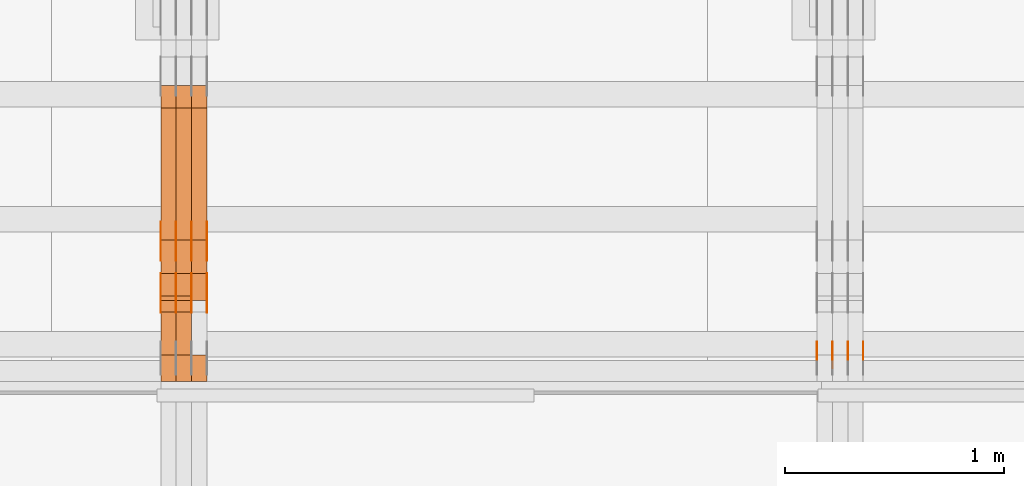
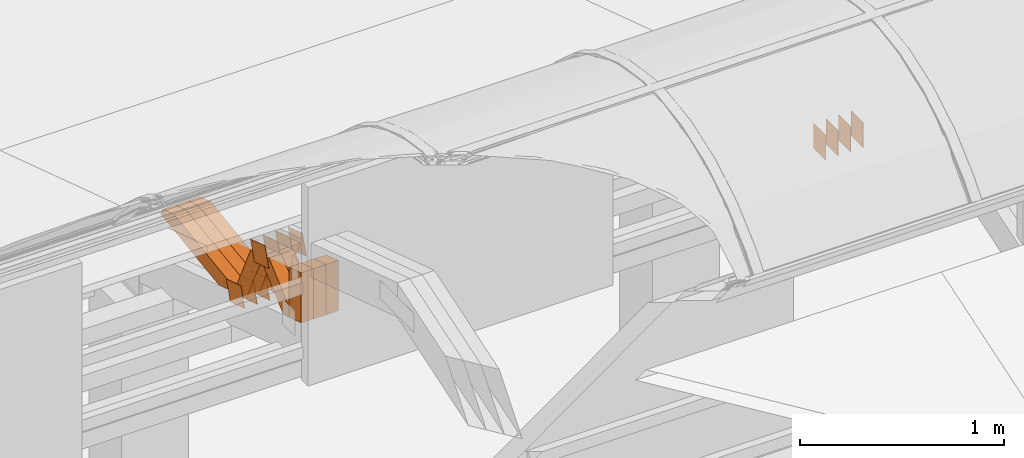
# One storey, part 289 of 385: 29 proxies.
"""IFC2X3 building model written with IfcOpenShell, lengths in millimetres."""

from ifc_helpers import new_model, entity, si_unit, converted_unit, derived_unit, direction, frame, origin, origin_2d_with_axis, place, context, subcontext, project, spatial, polyline, rectangle, outline, extrude, source, transform, mapped, material, type_object, type_shapes, element, save


model = new_model("IFC2X3")

# Units and contexts
model_context = context("Model", 3, precision=0.01, world=origin(), true_north=direction((6.12303176911189e-17, 1.0)))
body_context = subcontext(model_context, "Body", "Model", "MODEL_VIEW")
ifc_project = project(units=[si_unit("LENGTHUNIT", "METRE", prefix="MILLI"), si_unit("AREAUNIT", "SQUARE_METRE"), si_unit("VOLUMEUNIT", "CUBIC_METRE"), converted_unit("PLANEANGLEUNIT", "DEGREE", entity("IfcRatioMeasure", 0.0174532925199433), si_unit("PLANEANGLEUNIT", "RADIAN"), dimensions=[0, 0, 0, 0, 0, 0, 0]), si_unit("MASSUNIT", "GRAM", prefix="KILO"), derived_unit("MASSDENSITYUNIT", [(si_unit("MASSUNIT", "GRAM", prefix="KILO"), 1), (si_unit("LENGTHUNIT", "METRE"), -3)]), si_unit("TIMEUNIT", "SECOND"), si_unit("FREQUENCYUNIT", "HERTZ"), si_unit("THERMODYNAMICTEMPERATUREUNIT", "DEGREE_CELSIUS"), derived_unit("THERMALTRANSMITTANCEUNIT", [(si_unit("MASSUNIT", "GRAM", prefix="KILO"), 1), (si_unit("THERMODYNAMICTEMPERATUREUNIT", "KELVIN"), -1), (si_unit("TIMEUNIT", "SECOND"), -3)]), derived_unit("VOLUMETRICFLOWRATEUNIT", [(si_unit("LENGTHUNIT", "METRE"), 3), (si_unit("TIMEUNIT", "SECOND"), -1)]), si_unit("ELECTRICCURRENTUNIT", "AMPERE"), si_unit("ELECTRICVOLTAGEUNIT", "VOLT"), si_unit("POWERUNIT", "WATT"), si_unit("FORCEUNIT", "NEWTON", prefix="KILO"), si_unit("ILLUMINANCEUNIT", "LUX"), si_unit("LUMINOUSFLUXUNIT", "LUMEN"), si_unit("LUMINOUSINTENSITYUNIT", "CANDELA"), derived_unit("USERDEFINED", [(si_unit("MASSUNIT", "GRAM", prefix="KILO"), -1), (si_unit("LENGTHUNIT", "METRE"), -2), (si_unit("TIMEUNIT", "SECOND"), 3), (si_unit("LUMINOUSFLUXUNIT", "LUMEN"), 1)]), derived_unit("LINEARVELOCITYUNIT", [(si_unit("LENGTHUNIT", "METRE"), 1), (si_unit("TIMEUNIT", "SECOND"), -1)]), si_unit("PRESSUREUNIT", "PASCAL"), derived_unit("USERDEFINED", [(si_unit("LENGTHUNIT", "METRE"), -2), (si_unit("MASSUNIT", "GRAM", prefix="KILO"), 1), (si_unit("TIMEUNIT", "SECOND"), -2)])], contexts=[model_context])

# Site, building, storey
site_placement = place(None, origin())
site = spatial("IfcSite", under=ifc_project, at=site_placement, CompositionType="ELEMENT")
building_placement = place(site_placement, origin())
building = spatial("IfcBuilding", under=site, at=building_placement, CompositionType="ELEMENT")
storey_placement = place(building_placement, origin())
storey = spatial("IfcBuildingStorey", under=building, at=storey_placement, Name="Default", CompositionType="ELEMENT", Elevation=0.0)

# Proxies
ifc_material_1 = material(Name="IfcSurfaceStyle #480834")
building_element_proxy_type_1 = type_object("IfcBuildingElementProxyType", PredefinedType="NOTDEFINED", material=ifc_material_1)
shared_shape_1 = source(origin(), body_context, "Body", "SweptSolid", [
    extrude(rectangle(XDim=150.0, YDim=120.0, at=origin_2d_with_axis()), frame((75.0, 60.0, 0.0), z_axis=(0.0, 0.0, 1.0), x_axis=(-1.0, 0.0, 0.0)), (0.0, 0.0, 1.0), 1.3),
])
type_shapes(building_element_proxy_type_1, [shared_shape_1])
proxy_1_placement = place(building_placement, frame((39386.3, 15840.0, 3652.70166015625), z_axis=(-1.0, 0.0, 0.0), x_axis=(0.0, 0.0, -1.0)))
element("IfcBuildingElementProxy", 1, at=proxy_1_placement, inside=storey, type_object=building_element_proxy_type_1, material=ifc_material_1, context=body_context, shape_type="MappedRepresentation", body=[
    mapped(shared_shape_1, transform((0.0, 0.0, 0.0), scale=1.0)),
])
ifc_material_2 = material(Name="IfcSurfaceStyle #480777")
building_element_proxy_type_2 = type_object("IfcBuildingElementProxyType", PredefinedType="NOTDEFINED", material=ifc_material_2)
shared_shape_2 = source(origin(), body_context, "Body", "SweptSolid", [
    extrude(rectangle(XDim=150.0, YDim=120.0, at=origin_2d_with_axis()), frame((75.0, 60.0, 0.0), z_axis=(0.0, 0.0, 1.0), x_axis=(-1.0, 0.0, 0.0)), (0.0, 0.0, 1.0), 1.3),
])
type_shapes(building_element_proxy_type_2, [shared_shape_2])
proxy_2_placement = place(building_placement, frame((39315.0, 15840.0, 3652.70166015625), z_axis=(-1.0, 0.0, 0.0), x_axis=(0.0, 0.0, -1.0)))
element("IfcBuildingElementProxy", 2, at=proxy_2_placement, inside=storey, type_object=building_element_proxy_type_2, material=ifc_material_2, context=body_context, shape_type="MappedRepresentation", body=[
    mapped(shared_shape_2, transform((0.0, 0.0, 0.0), scale=1.0)),
])
ifc_material_3 = material(Name="IfcSurfaceStyle #480720")
building_element_proxy_type_3 = type_object("IfcBuildingElementProxyType", PredefinedType="NOTDEFINED", material=ifc_material_3)
shared_shape_3 = source(origin(), body_context, "Body", "SweptSolid", [
    extrude(rectangle(XDim=150.0, YDim=120.0, at=origin_2d_with_axis()), frame((75.0, 60.0, 0.0), z_axis=(0.0, 0.0, 1.0), x_axis=(-1.0, 0.0, 0.0)), (0.0, 0.0, 1.0), 1.3),
])
type_shapes(building_element_proxy_type_3, [shared_shape_3])
proxy_3_placement = place(building_placement, frame((39316.3, 15840.0, 3652.70166015625), z_axis=(-1.0, 0.0, 0.0), x_axis=(0.0, 0.0, -1.0)))
element("IfcBuildingElementProxy", 3, at=proxy_3_placement, inside=storey, type_object=building_element_proxy_type_3, material=ifc_material_3, context=body_context, shape_type="MappedRepresentation", body=[
    mapped(shared_shape_3, transform((0.0, 0.0, 0.0), scale=1.0)),
])
ifc_material_4 = material(Name="IfcSurfaceStyle #480663")
building_element_proxy_type_4 = type_object("IfcBuildingElementProxyType", PredefinedType="NOTDEFINED", material=ifc_material_4)
shared_shape_4 = source(origin(), body_context, "Body", "SweptSolid", [
    extrude(rectangle(XDim=150.0, YDim=120.0, at=origin_2d_with_axis()), frame((75.0, 60.0, 0.0), z_axis=(0.0, 0.0, 1.0), x_axis=(-1.0, 0.0, 0.0)), (0.0, 0.0, 1.0), 1.29999999999999),
])
type_shapes(building_element_proxy_type_4, [shared_shape_4])
proxy_4_placement = place(building_placement, frame((39245.0, 15840.0, 3652.70166015625), z_axis=(-1.0, 0.0, 0.0), x_axis=(0.0, 0.0, -1.0)))
element("IfcBuildingElementProxy", 4, at=proxy_4_placement, inside=storey, type_object=building_element_proxy_type_4, material=ifc_material_4, context=body_context, shape_type="MappedRepresentation", body=[
    mapped(shared_shape_4, transform((0.0, 0.0, 0.0), scale=1.0)),
])
ifc_material_5 = material(Name="IfcSurfaceStyle #480606")
building_element_proxy_type_5 = type_object("IfcBuildingElementProxyType", PredefinedType="NOTDEFINED", material=ifc_material_5)
shared_shape_5 = source(origin(), body_context, "Body", "SweptSolid", [
    extrude(rectangle(XDim=150.0, YDim=120.0, at=origin_2d_with_axis()), frame((75.0, 60.0, 0.0), z_axis=(0.0, 0.0, 1.0), x_axis=(-1.0, 0.0, 0.0)), (0.0, 0.0, 1.0), 1.29999999999999),
])
type_shapes(building_element_proxy_type_5, [shared_shape_5])
proxy_5_placement = place(building_placement, frame((39246.3, 15840.0, 3652.70166015625), z_axis=(-1.0, 0.0, 0.0), x_axis=(0.0, 0.0, -1.0)))
element("IfcBuildingElementProxy", 5, at=proxy_5_placement, inside=storey, type_object=building_element_proxy_type_5, material=ifc_material_5, context=body_context, shape_type="MappedRepresentation", body=[
    mapped(shared_shape_5, transform((0.0, 0.0, 0.0), scale=1.0)),
])
ifc_material_6 = material(Name="IfcSurfaceStyle #480549")
building_element_proxy_type_6 = type_object("IfcBuildingElementProxyType", PredefinedType="NOTDEFINED", material=ifc_material_6)
shared_shape_6 = source(origin(), body_context, "Body", "SweptSolid", [
    extrude(rectangle(XDim=150.0, YDim=120.0, at=origin_2d_with_axis()), frame((75.0, 60.0, 0.0), z_axis=(0.0, 0.0, 1.0), x_axis=(-1.0, 0.0, 0.0)), (0.0, 0.0, 1.0), 1.29999999999999),
])
type_shapes(building_element_proxy_type_6, [shared_shape_6])
proxy_6_placement = place(building_placement, frame((39175.0, 15840.0, 3652.70166015625), z_axis=(-1.0, 0.0, 0.0), x_axis=(0.0, 0.0, -1.0)))
element("IfcBuildingElementProxy", 6, at=proxy_6_placement, inside=storey, type_object=building_element_proxy_type_6, material=ifc_material_6, context=body_context, shape_type="MappedRepresentation", body=[
    mapped(shared_shape_6, transform((0.0, 0.0, 0.0), scale=1.0)),
])
ifc_material_7 = material(Name="IfcSurfaceStyle #446060")
building_element_proxy_type_7 = type_object("IfcBuildingElementProxyType", PredefinedType="NOTDEFINED", material=ifc_material_7)
shared_shape_7 = source(origin(), body_context, "Body", "SweptSolid", [
    extrude(outline(polyline([(-74.9998605591118, -59.9999264677601), (74.9998754286171, -59.9999264677601), (74.9998605591118, 59.9999264677602), (-74.9998754286171, 59.9999264677602), (-74.9998605591118, -59.9999264677601)])), frame((74.9998754286171, 60.0000503992849, 0.0), z_axis=(0.0, 0.0, 1.0), x_axis=(-1.0, 0.0, 0.0)), (0.0, 0.0, 1.0), 1.3),
])
type_shapes(building_element_proxy_type_7, [shared_shape_7])
proxy_7_placement = place(building_placement, frame((36386.3, 16352.8320303235, 3323.23212676408), z_axis=(-1.0, 0.0, 0.0), x_axis=(0.0, -0.951056516295124, 0.309016994375039)))
element("IfcBuildingElementProxy", 7, at=proxy_7_placement, inside=storey, type_object=building_element_proxy_type_7, material=ifc_material_7, context=body_context, shape_type="MappedRepresentation", body=[
    mapped(shared_shape_7, transform((0.0, 0.0, 0.0), scale=1.0)),
])
ifc_material_8 = material(Name="IfcSurfaceStyle #446003")
building_element_proxy_type_8 = type_object("IfcBuildingElementProxyType", PredefinedType="NOTDEFINED", material=ifc_material_8)
shared_shape_8 = source(origin(), body_context, "Body", "SweptSolid", [
    extrude(outline(polyline([(-74.9998605591118, -59.9999264677601), (74.9998754286171, -59.9999264677601), (74.9998605591118, 59.9999264677602), (-74.9998754286171, 59.9999264677602), (-74.9998605591118, -59.9999264677601)])), frame((74.9998754286171, 60.0000503992849, 0.0), z_axis=(0.0, 0.0, 1.0), x_axis=(-1.0, 0.0, 0.0)), (0.0, 0.0, 1.0), 1.3),
])
type_shapes(building_element_proxy_type_8, [shared_shape_8])
proxy_8_placement = place(building_placement, frame((36315.0, 16352.8320303235, 3323.23212676408), z_axis=(-1.0, 0.0, 0.0), x_axis=(0.0, -0.951056516295124, 0.309016994375039)))
element("IfcBuildingElementProxy", 8, at=proxy_8_placement, inside=storey, type_object=building_element_proxy_type_8, material=ifc_material_8, context=body_context, shape_type="MappedRepresentation", body=[
    mapped(shared_shape_8, transform((0.0, 0.0, 0.0), scale=1.0)),
])
ifc_material_9 = material(Name="IfcSurfaceStyle #445946")
building_element_proxy_type_9 = type_object("IfcBuildingElementProxyType", PredefinedType="NOTDEFINED", material=ifc_material_9)
shared_shape_9 = source(origin(), body_context, "Body", "SweptSolid", [
    extrude(outline(polyline([(-74.9998605591118, -59.9999264677601), (74.9998754286171, -59.9999264677601), (74.9998605591118, 59.9999264677602), (-74.9998754286171, 59.9999264677602), (-74.9998605591118, -59.9999264677601)])), frame((74.9998754286171, 60.0000503992849, 0.0), z_axis=(0.0, 0.0, 1.0), x_axis=(-1.0, 0.0, 0.0)), (0.0, 0.0, 1.0), 1.3),
])
type_shapes(building_element_proxy_type_9, [shared_shape_9])
proxy_9_placement = place(building_placement, frame((36316.3, 16352.8320303235, 3323.23212676408), z_axis=(-1.0, 0.0, 0.0), x_axis=(0.0, -0.951056516295124, 0.309016994375039)))
element("IfcBuildingElementProxy", 9, at=proxy_9_placement, inside=storey, type_object=building_element_proxy_type_9, material=ifc_material_9, context=body_context, shape_type="MappedRepresentation", body=[
    mapped(shared_shape_9, transform((0.0, 0.0, 0.0), scale=1.0)),
])
ifc_material_10 = material(Name="IfcSurfaceStyle #445889")
building_element_proxy_type_10 = type_object("IfcBuildingElementProxyType", PredefinedType="NOTDEFINED", material=ifc_material_10)
shared_shape_10 = source(origin(), body_context, "Body", "SweptSolid", [
    extrude(outline(polyline([(-74.9998605591118, -59.9999264677601), (74.9998754286171, -59.9999264677601), (74.9998605591118, 59.9999264677602), (-74.9998754286171, 59.9999264677602), (-74.9998605591118, -59.9999264677601)])), frame((74.9998754286171, 60.0000503992849, 0.0), z_axis=(0.0, 0.0, 1.0), x_axis=(-1.0, 0.0, 0.0)), (0.0, 0.0, 1.0), 1.29999999999999),
])
type_shapes(building_element_proxy_type_10, [shared_shape_10])
proxy_10_placement = place(building_placement, frame((36245.0, 16352.8320303235, 3323.23212676408), z_axis=(-1.0, 0.0, 0.0), x_axis=(0.0, -0.951056516295124, 0.309016994375039)))
element("IfcBuildingElementProxy", 10, at=proxy_10_placement, inside=storey, type_object=building_element_proxy_type_10, material=ifc_material_10, context=body_context, shape_type="MappedRepresentation", body=[
    mapped(shared_shape_10, transform((0.0, 0.0, 0.0), scale=1.0)),
])
ifc_material_11 = material(Name="IfcSurfaceStyle #445832")
building_element_proxy_type_11 = type_object("IfcBuildingElementProxyType", PredefinedType="NOTDEFINED", material=ifc_material_11)
shared_shape_11 = source(origin(), body_context, "Body", "SweptSolid", [
    extrude(outline(polyline([(-74.9998605591118, -59.9999264677601), (74.9998754286171, -59.9999264677601), (74.9998605591118, 59.9999264677602), (-74.9998754286171, 59.9999264677602), (-74.9998605591118, -59.9999264677601)])), frame((74.9998754286171, 60.0000503992849, 0.0), z_axis=(0.0, 0.0, 1.0), x_axis=(-1.0, 0.0, 0.0)), (0.0, 0.0, 1.0), 1.29999999999999),
])
type_shapes(building_element_proxy_type_11, [shared_shape_11])
proxy_11_placement = place(building_placement, frame((36246.3, 16352.8320303235, 3323.23212676408), z_axis=(-1.0, 0.0, 0.0), x_axis=(0.0, -0.951056516295124, 0.309016994375039)))
element("IfcBuildingElementProxy", 11, at=proxy_11_placement, inside=storey, type_object=building_element_proxy_type_11, material=ifc_material_11, context=body_context, shape_type="MappedRepresentation", body=[
    mapped(shared_shape_11, transform((0.0, 0.0, 0.0), scale=1.0)),
])
ifc_material_12 = material(Name="IfcSurfaceStyle #445775")
building_element_proxy_type_12 = type_object("IfcBuildingElementProxyType", PredefinedType="NOTDEFINED", material=ifc_material_12)
shared_shape_12 = source(origin(), body_context, "Body", "SweptSolid", [
    extrude(outline(polyline([(-74.9998605591118, -59.9999264677601), (74.9998754286171, -59.9999264677601), (74.9998605591118, 59.9999264677602), (-74.9998754286171, 59.9999264677602), (-74.9998605591118, -59.9999264677601)])), frame((74.9998754286171, 60.0000503992849, 0.0), z_axis=(0.0, 0.0, 1.0), x_axis=(-1.0, 0.0, 0.0)), (0.0, 0.0, 1.0), 1.29999999999999),
])
type_shapes(building_element_proxy_type_12, [shared_shape_12])
proxy_12_placement = place(building_placement, frame((36175.0, 16352.8320303235, 3323.23212676408), z_axis=(-1.0, 0.0, 0.0), x_axis=(0.0, -0.951056516295124, 0.309016994375039)))
element("IfcBuildingElementProxy", 12, at=proxy_12_placement, inside=storey, type_object=building_element_proxy_type_12, material=ifc_material_12, context=body_context, shape_type="MappedRepresentation", body=[
    mapped(shared_shape_12, transform((0.0, 0.0, 0.0), scale=1.0)),
])
ifc_material_13 = material(Name="IfcSurfaceStyle #441614")
building_element_proxy_type_13 = type_object("IfcBuildingElementProxyType", PredefinedType="NOTDEFINED", material=ifc_material_13)
shared_shape_13 = source(origin(), body_context, "Body", "SweptSolid", [
    extrude(outline(polyline([(-75.0003249421702, -60.0000773549573), (75.0003398116874, -60.0000773549573), (75.0003249421711, 60.0000773549573), (-75.0003398116883, 60.0000773549573), (-75.0003249421702, -60.0000773549573)])), frame((75.0003398116874, 60.0000773549573, 0.0), z_axis=(0.0, 0.0, 1.0), x_axis=(-1.0, 0.0, 0.0)), (0.0, 0.0, 1.0), 1.3),
])
type_shapes(building_element_proxy_type_13, [shared_shape_13])
proxy_13_placement = place(building_placement, frame((36386.3, 16117.0849050545, 3705.49074668796), z_axis=(-1.0, 0.0, 0.0), x_axis=(0.0, -0.951056516295154, 0.309016994374948)))
element("IfcBuildingElementProxy", 13, at=proxy_13_placement, inside=storey, type_object=building_element_proxy_type_13, material=ifc_material_13, context=body_context, shape_type="MappedRepresentation", body=[
    mapped(shared_shape_13, transform((0.0, 0.0, 0.0), scale=1.0)),
])
ifc_material_14 = material(Name="IfcSurfaceStyle #441557")
building_element_proxy_type_14 = type_object("IfcBuildingElementProxyType", PredefinedType="NOTDEFINED", material=ifc_material_14)
shared_shape_14 = source(origin(), body_context, "Body", "SweptSolid", [
    extrude(outline(polyline([(-75.0003249421702, -60.0000773549573), (75.0003398116874, -60.0000773549573), (75.0003249421711, 60.0000773549573), (-75.0003398116883, 60.0000773549573), (-75.0003249421702, -60.0000773549573)])), frame((75.0003398116874, 60.0000773549573, 0.0), z_axis=(0.0, 0.0, 1.0), x_axis=(-1.0, 0.0, 0.0)), (0.0, 0.0, 1.0), 1.3),
])
type_shapes(building_element_proxy_type_14, [shared_shape_14])
proxy_14_placement = place(building_placement, frame((36315.0, 16117.0849050545, 3705.49074668796), z_axis=(-1.0, 0.0, 0.0), x_axis=(0.0, -0.951056516295154, 0.309016994374948)))
element("IfcBuildingElementProxy", 14, at=proxy_14_placement, inside=storey, type_object=building_element_proxy_type_14, material=ifc_material_14, context=body_context, shape_type="MappedRepresentation", body=[
    mapped(shared_shape_14, transform((0.0, 0.0, 0.0), scale=1.0)),
])
ifc_material_15 = material(Name="IfcSurfaceStyle #441500")
building_element_proxy_type_15 = type_object("IfcBuildingElementProxyType", PredefinedType="NOTDEFINED", material=ifc_material_15)
shared_shape_15 = source(origin(), body_context, "Body", "SweptSolid", [
    extrude(outline(polyline([(-75.0003249421702, -60.0000773549573), (75.0003398116874, -60.0000773549573), (75.0003249421711, 60.0000773549573), (-75.0003398116883, 60.0000773549573), (-75.0003249421702, -60.0000773549573)])), frame((75.0003398116874, 60.0000773549573, 0.0), z_axis=(0.0, 0.0, 1.0), x_axis=(-1.0, 0.0, 0.0)), (0.0, 0.0, 1.0), 1.3),
])
type_shapes(building_element_proxy_type_15, [shared_shape_15])
proxy_15_placement = place(building_placement, frame((36316.3, 16117.0849050545, 3705.49074668796), z_axis=(-1.0, 0.0, 0.0), x_axis=(0.0, -0.951056516295154, 0.309016994374948)))
element("IfcBuildingElementProxy", 15, at=proxy_15_placement, inside=storey, type_object=building_element_proxy_type_15, material=ifc_material_15, context=body_context, shape_type="MappedRepresentation", body=[
    mapped(shared_shape_15, transform((0.0, 0.0, 0.0), scale=1.0)),
])
ifc_material_16 = material(Name="IfcSurfaceStyle #441443")
building_element_proxy_type_16 = type_object("IfcBuildingElementProxyType", PredefinedType="NOTDEFINED", material=ifc_material_16)
shared_shape_16 = source(origin(), body_context, "Body", "SweptSolid", [
    extrude(outline(polyline([(-75.0003249421702, -60.0000773549573), (75.0003398116874, -60.0000773549573), (75.0003249421711, 60.0000773549573), (-75.0003398116883, 60.0000773549573), (-75.0003249421702, -60.0000773549573)])), frame((75.0003398116874, 60.0000773549573, 0.0), z_axis=(0.0, 0.0, 1.0), x_axis=(-1.0, 0.0, 0.0)), (0.0, 0.0, 1.0), 1.29999999999999),
])
type_shapes(building_element_proxy_type_16, [shared_shape_16])
proxy_16_placement = place(building_placement, frame((36245.0, 16117.0849050545, 3705.49074668796), z_axis=(-1.0, 0.0, 0.0), x_axis=(0.0, -0.951056516295154, 0.309016994374948)))
element("IfcBuildingElementProxy", 16, at=proxy_16_placement, inside=storey, type_object=building_element_proxy_type_16, material=ifc_material_16, context=body_context, shape_type="MappedRepresentation", body=[
    mapped(shared_shape_16, transform((0.0, 0.0, 0.0), scale=1.0)),
])
ifc_material_17 = material(Name="IfcSurfaceStyle #441386")
building_element_proxy_type_17 = type_object("IfcBuildingElementProxyType", PredefinedType="NOTDEFINED", material=ifc_material_17)
shared_shape_17 = source(origin(), body_context, "Body", "SweptSolid", [
    extrude(outline(polyline([(-75.0003249421702, -60.0000773549573), (75.0003398116874, -60.0000773549573), (75.0003249421711, 60.0000773549573), (-75.0003398116883, 60.0000773549573), (-75.0003249421702, -60.0000773549573)])), frame((75.0003398116874, 60.0000773549573, 0.0), z_axis=(0.0, 0.0, 1.0), x_axis=(-1.0, 0.0, 0.0)), (0.0, 0.0, 1.0), 1.29999999999999),
])
type_shapes(building_element_proxy_type_17, [shared_shape_17])
proxy_17_placement = place(building_placement, frame((36246.3, 16117.0849050545, 3705.49074668796), z_axis=(-1.0, 0.0, 0.0), x_axis=(0.0, -0.951056516295154, 0.309016994374948)))
element("IfcBuildingElementProxy", 17, at=proxy_17_placement, inside=storey, type_object=building_element_proxy_type_17, material=ifc_material_17, context=body_context, shape_type="MappedRepresentation", body=[
    mapped(shared_shape_17, transform((0.0, 0.0, 0.0), scale=1.0)),
])
ifc_material_18 = material(Name="IfcSurfaceStyle #441329")
building_element_proxy_type_18 = type_object("IfcBuildingElementProxyType", PredefinedType="NOTDEFINED", material=ifc_material_18)
shared_shape_18 = source(origin(), body_context, "Body", "SweptSolid", [
    extrude(outline(polyline([(-75.0003249421702, -60.0000773549573), (75.0003398116874, -60.0000773549573), (75.0003249421711, 60.0000773549573), (-75.0003398116883, 60.0000773549573), (-75.0003249421702, -60.0000773549573)])), frame((75.0003398116874, 60.0000773549573, 0.0), z_axis=(0.0, 0.0, 1.0), x_axis=(-1.0, 0.0, 0.0)), (0.0, 0.0, 1.0), 1.29999999999999),
])
type_shapes(building_element_proxy_type_18, [shared_shape_18])
proxy_18_placement = place(building_placement, frame((36175.0, 16117.0849050545, 3705.49074668796), z_axis=(-1.0, 0.0, 0.0), x_axis=(0.0, -0.951056516295154, 0.309016994374948)))
element("IfcBuildingElementProxy", 18, at=proxy_18_placement, inside=storey, type_object=building_element_proxy_type_18, material=ifc_material_18, context=body_context, shape_type="MappedRepresentation", body=[
    mapped(shared_shape_18, transform((0.0, 0.0, 0.0), scale=1.0)),
])
ifc_material_19 = material(Name="IfcSurfaceStyle #431486")
building_element_proxy_type_19 = type_object("IfcBuildingElementProxyType", Name="T1-W50 431484", PredefinedType="NOTDEFINED", material=ifc_material_19)
shared_shape_19 = source(origin(), body_context, "Body", "SweptSolid", [
    extrude(outline(polyline([(-128.56619634284, -47.4999385885712), (133.151257249084, -47.4999385885712), (161.172800006526, -0.000129729183733609), (147.291467726413, 47.500068317755), (-142.513973767368, 47.500068317755), (-170.535354871815, -0.000129729183754689), (-128.56619634284, -47.4999385885712)])), frame((161.17310141218, 47.5001898716564, 0.0), z_axis=(0.0, 0.0, 1.0), x_axis=(-1.0, 0.0, 0.0)), (0.0, 0.0, 1.0), 70.0),
])
type_shapes(building_element_proxy_type_19, [shared_shape_19])
proxy_19_placement = place(building_placement, frame((36315.0, 16060.0297689714, 3761.73994820667), z_axis=(-1.0, 0.0, 0.0), x_axis=(0.0, -0.749388407538668, -0.662130662820156)))
element("IfcBuildingElementProxy", 19, at=proxy_19_placement, inside=storey, type_object=building_element_proxy_type_19, material=ifc_material_19, Name="T1-W50", context=body_context, shape_type="MappedRepresentation", body=[
    mapped(shared_shape_19, transform((0.0, 0.0, 0.0), scale=1.0)),
])
ifc_material_20 = material(Name="IfcSurfaceStyle #431411")
building_element_proxy_type_20 = type_object("IfcBuildingElementProxyType", Name="T1-W50 431409", PredefinedType="NOTDEFINED", material=ifc_material_20)
shared_shape_20 = source(origin(), body_context, "Body", "SweptSolid", [
    extrude(outline(polyline([(-128.56619634284, -47.4999385885712), (133.151257249084, -47.4999385885712), (161.172800006526, -0.000129729183733609), (147.291467726413, 47.500068317755), (-142.513973767368, 47.500068317755), (-170.535354871815, -0.000129729183754689), (-128.56619634284, -47.4999385885712)])), frame((161.17310141218, 47.5001898716564, 0.0), z_axis=(0.0, 0.0, 1.0), x_axis=(-1.0, 0.0, 0.0)), (0.0, 0.0, 1.0), 70.0),
])
type_shapes(building_element_proxy_type_20, [shared_shape_20])
proxy_20_placement = place(building_placement, frame((36245.0, 16060.0297689714, 3761.73994820667), z_axis=(-1.0, 0.0, 0.0), x_axis=(0.0, -0.749388407538668, -0.662130662820156)))
element("IfcBuildingElementProxy", 20, at=proxy_20_placement, inside=storey, type_object=building_element_proxy_type_20, material=ifc_material_20, Name="T1-W50", context=body_context, shape_type="MappedRepresentation", body=[
    mapped(shared_shape_20, transform((0.0, 0.0, 0.0), scale=1.0)),
])
ifc_material_21 = material(Name="IfcSurfaceStyle #431165")
building_element_proxy_type_21 = type_object("IfcBuildingElementProxyType", Name="T1-W2 431163", PredefinedType="NOTDEFINED", material=ifc_material_21)
shared_shape_21 = source(origin(), body_context, "Body", "SweptSolid", [
    extrude(outline(polyline([(-130.705993652344, -60.0), (169.696350097656, -60.0), (130.706115722656, 60.0), (-169.696472167969, 60.0), (-130.705993652344, -60.0)])), frame((169.696429629256, 60.0, 0.0), z_axis=(0.0, 0.0, 1.0), x_axis=(-1.0, 0.0, 0.0)), (0.0, 0.0, 1.0), 70.0),
])
type_shapes(building_element_proxy_type_21, [shared_shape_21])
proxy_21_placement = place(building_placement, frame((36385.0, 15660.0, 3577.70158062465), z_axis=(-1.0, 0.0, 0.0), x_axis=(0.0, 0.0, 1.0)))
element("IfcBuildingElementProxy", 21, at=proxy_21_placement, inside=storey, type_object=building_element_proxy_type_21, material=ifc_material_21, Name="T1-W2", context=body_context, shape_type="MappedRepresentation", body=[
    mapped(shared_shape_21, transform((0.0, 0.0, 0.0), scale=1.0)),
])
ifc_material_22 = material(Name="IfcSurfaceStyle #431108")
building_element_proxy_type_22 = type_object("IfcBuildingElementProxyType", Name="T1-W2 431106", PredefinedType="NOTDEFINED", material=ifc_material_22)
shared_shape_22 = source(origin(), body_context, "Body", "SweptSolid", [
    extrude(outline(polyline([(-130.705993652344, -60.0), (169.696350097656, -60.0), (130.706115722656, 60.0), (-169.696472167969, 60.0), (-130.705993652344, -60.0)])), frame((169.696429629256, 60.0, 0.0), z_axis=(0.0, 0.0, 1.0), x_axis=(-1.0, 0.0, 0.0)), (0.0, 0.0, 1.0), 70.0),
])
type_shapes(building_element_proxy_type_22, [shared_shape_22])
proxy_22_placement = place(building_placement, frame((36315.0, 15660.0, 3577.70158062465), z_axis=(-1.0, 0.0, 0.0), x_axis=(0.0, 0.0, 1.0)))
element("IfcBuildingElementProxy", 22, at=proxy_22_placement, inside=storey, type_object=building_element_proxy_type_22, material=ifc_material_22, Name="T1-W2", context=body_context, shape_type="MappedRepresentation", body=[
    mapped(shared_shape_22, transform((0.0, 0.0, 0.0), scale=1.0)),
])
ifc_material_23 = material(Name="IfcSurfaceStyle #431051")
building_element_proxy_type_23 = type_object("IfcBuildingElementProxyType", Name="T1-W2 431049", PredefinedType="NOTDEFINED", material=ifc_material_23)
shared_shape_23 = source(origin(), body_context, "Body", "SweptSolid", [
    extrude(outline(polyline([(-130.705993652344, -60.0), (169.696350097656, -60.0), (130.706115722656, 60.0), (-169.696472167969, 60.0), (-130.705993652344, -60.0)])), frame((169.696429629256, 60.0, 0.0), z_axis=(0.0, 0.0, 1.0), x_axis=(-1.0, 0.0, 0.0)), (0.0, 0.0, 1.0), 70.0),
])
type_shapes(building_element_proxy_type_23, [shared_shape_23])
proxy_23_placement = place(building_placement, frame((36245.0, 15660.0, 3577.70158062465), z_axis=(-1.0, 0.0, 0.0), x_axis=(0.0, 0.0, 1.0)))
element("IfcBuildingElementProxy", 23, at=proxy_23_placement, inside=storey, type_object=building_element_proxy_type_23, material=ifc_material_23, Name="T1-W2", context=body_context, shape_type="MappedRepresentation", body=[
    mapped(shared_shape_23, transform((0.0, 0.0, 0.0), scale=1.0)),
])
ifc_material_24 = material(Name="IfcSurfaceStyle #430994")
building_element_proxy_type_24 = type_object("IfcBuildingElementProxyType", Name="T1-W44 430992", PredefinedType="NOTDEFINED", material=ifc_material_24)
shared_shape_24 = source(origin(), body_context, "Body", "SweptSolid", [
    extrude(outline(polyline([(-184.551057772692, -47.4997984945814), (177.527112951531, -47.4997984945814), (162.630077773546, -0.000452497529500495), (118.068221667048, 47.5000247433462), (-273.674354619433, 47.5000247433462), (-184.551057772692, -47.4997984945814)])), frame((177.527112951531, 47.5002721629815, 0.0), z_axis=(0.0, 0.0, 1.0), x_axis=(-1.0, 0.0, 0.0)), (0.0, 0.0, 1.0), 70.0),
])
type_shapes(building_element_proxy_type_24, [shared_shape_24])
proxy_24_placement = place(building_placement, frame((36385.0, 16220.4899216004, 3388.98238154171), z_axis=(-1.0, 0.0, 0.0), x_axis=(0.0, -0.425335045192995, 0.905035965766374)))
element("IfcBuildingElementProxy", 24, at=proxy_24_placement, inside=storey, type_object=building_element_proxy_type_24, material=ifc_material_24, Name="T1-W44", context=body_context, shape_type="MappedRepresentation", body=[
    mapped(shared_shape_24, transform((0.0, 0.0, 0.0), scale=1.0)),
])
ifc_material_25 = material(Name="IfcSurfaceStyle #430928")
building_element_proxy_type_25 = type_object("IfcBuildingElementProxyType", Name="T1-W44 430926", PredefinedType="NOTDEFINED", material=ifc_material_25)
shared_shape_25 = source(origin(), body_context, "Body", "SweptSolid", [
    extrude(outline(polyline([(-184.551057772692, -47.4997984945814), (177.527112951531, -47.4997984945814), (162.630077773546, -0.000452497529500495), (118.068221667048, 47.5000247433462), (-273.674354619433, 47.5000247433462), (-184.551057772692, -47.4997984945814)])), frame((177.527112951531, 47.5002721629815, 0.0), z_axis=(0.0, 0.0, 1.0), x_axis=(-1.0, 0.0, 0.0)), (0.0, 0.0, 1.0), 70.0),
])
type_shapes(building_element_proxy_type_25, [shared_shape_25])
proxy_25_placement = place(building_placement, frame((36315.0, 16220.4899216004, 3388.98238154171), z_axis=(-1.0, 0.0, 0.0), x_axis=(0.0, -0.425335045192995, 0.905035965766374)))
element("IfcBuildingElementProxy", 25, at=proxy_25_placement, inside=storey, type_object=building_element_proxy_type_25, material=ifc_material_25, Name="T1-W44", context=body_context, shape_type="MappedRepresentation", body=[
    mapped(shared_shape_25, transform((0.0, 0.0, 0.0), scale=1.0)),
])
ifc_material_26 = material(Name="IfcSurfaceStyle #430862")
building_element_proxy_type_26 = type_object("IfcBuildingElementProxyType", Name="T1-W44 430860", PredefinedType="NOTDEFINED", material=ifc_material_26)
shared_shape_26 = source(origin(), body_context, "Body", "SweptSolid", [
    extrude(outline(polyline([(-184.551057772692, -47.4997984945814), (177.527112951531, -47.4997984945814), (162.630077773546, -0.000452497529500495), (118.068221667048, 47.5000247433462), (-273.674354619433, 47.5000247433462), (-184.551057772692, -47.4997984945814)])), frame((177.527112951531, 47.5002721629815, 0.0), z_axis=(0.0, 0.0, 1.0), x_axis=(-1.0, 0.0, 0.0)), (0.0, 0.0, 1.0), 70.0),
])
type_shapes(building_element_proxy_type_26, [shared_shape_26])
proxy_26_placement = place(building_placement, frame((36245.0, 16220.4899216004, 3388.98238154171), z_axis=(-1.0, 0.0, 0.0), x_axis=(0.0, -0.425335045192995, 0.905035965766374)))
element("IfcBuildingElementProxy", 26, at=proxy_26_placement, inside=storey, type_object=building_element_proxy_type_26, material=ifc_material_26, Name="T1-W44", context=body_context, shape_type="MappedRepresentation", body=[
    mapped(shared_shape_26, transform((0.0, 0.0, 0.0), scale=1.0)),
])
ifc_material_27 = material(Name="IfcSurfaceStyle #430598")
building_element_proxy_type_27 = type_object("IfcBuildingElementProxyType", Name="T1-W8 430596", PredefinedType="NOTDEFINED", material=ifc_material_27)
shared_shape_27 = source(origin(), body_context, "Body", "SweptSolid", [
    extrude(outline(polyline([(-476.725263324644, -47.5001051695965), (180.672765845439, -47.5001051695965), (279.11020091716, -1.03605560390907e-06), (296.793624402619, 47.5001056876243), (-279.851327840575, 47.5001056876243), (-476.725263324644, -47.5001051695965)])), frame((296.793624402619, 47.5001056876243, 0.0), z_axis=(0.0, 0.0, 1.0), x_axis=(-1.0, 0.0, 0.0)), (0.0, 0.0, 1.0), 70.0),
])
type_shapes(building_element_proxy_type_27, [shared_shape_27])
proxy_27_placement = place(building_placement, frame((36385.0, 17036.40625, 3432.97192382813), z_axis=(-1.0, 0.0, 0.0), x_axis=(0.0, -0.990844046556832, -0.135011389900564)))
element("IfcBuildingElementProxy", 27, at=proxy_27_placement, inside=storey, type_object=building_element_proxy_type_27, material=ifc_material_27, Name="T1-W8", context=body_context, shape_type="MappedRepresentation", body=[
    mapped(shared_shape_27, transform((0.0, 0.0, 0.0), scale=1.0)),
])
ifc_material_28 = material(Name="IfcSurfaceStyle #430532")
building_element_proxy_type_28 = type_object("IfcBuildingElementProxyType", Name="T1-W8 430530", PredefinedType="NOTDEFINED", material=ifc_material_28)
shared_shape_28 = source(origin(), body_context, "Body", "SweptSolid", [
    extrude(outline(polyline([(-476.725263324644, -47.5001051695965), (180.672765845439, -47.5001051695965), (279.11020091716, -1.03605560390907e-06), (296.793624402619, 47.5001056876243), (-279.851327840575, 47.5001056876243), (-476.725263324644, -47.5001051695965)])), frame((296.793624402619, 47.5001056876243, 0.0), z_axis=(0.0, 0.0, 1.0), x_axis=(-1.0, 0.0, 0.0)), (0.0, 0.0, 1.0), 70.0),
])
type_shapes(building_element_proxy_type_28, [shared_shape_28])
proxy_28_placement = place(building_placement, frame((36315.0, 17036.40625, 3432.97192382813), z_axis=(-1.0, 0.0, 0.0), x_axis=(0.0, -0.990844046556832, -0.135011389900564)))
element("IfcBuildingElementProxy", 28, at=proxy_28_placement, inside=storey, type_object=building_element_proxy_type_28, material=ifc_material_28, Name="T1-W8", context=body_context, shape_type="MappedRepresentation", body=[
    mapped(shared_shape_28, transform((0.0, 0.0, 0.0), scale=1.0)),
])
ifc_material_29 = material(Name="IfcSurfaceStyle #430466")
building_element_proxy_type_29 = type_object("IfcBuildingElementProxyType", Name="T1-W8 430464", PredefinedType="NOTDEFINED", material=ifc_material_29)
shared_shape_29 = source(origin(), body_context, "Body", "SweptSolid", [
    extrude(outline(polyline([(-476.725263324644, -47.5001051695965), (180.672765845439, -47.5001051695965), (279.11020091716, -1.03605560390907e-06), (296.793624402619, 47.5001056876243), (-279.851327840575, 47.5001056876243), (-476.725263324644, -47.5001051695965)])), frame((296.793624402619, 47.5001056876243, 0.0), z_axis=(0.0, 0.0, 1.0), x_axis=(-1.0, 0.0, 0.0)), (0.0, 0.0, 1.0), 70.0),
])
type_shapes(building_element_proxy_type_29, [shared_shape_29])
proxy_29_placement = place(building_placement, frame((36245.0, 17036.40625, 3432.97192382813), z_axis=(-1.0, 0.0, 0.0), x_axis=(0.0, -0.990844046556832, -0.135011389900564)))
element("IfcBuildingElementProxy", 29, at=proxy_29_placement, inside=storey, type_object=building_element_proxy_type_29, material=ifc_material_29, Name="T1-W8", context=body_context, shape_type="MappedRepresentation", body=[
    mapped(shared_shape_29, transform((0.0, 0.0, 0.0), scale=1.0)),
])

save(model, "model.ifc")
